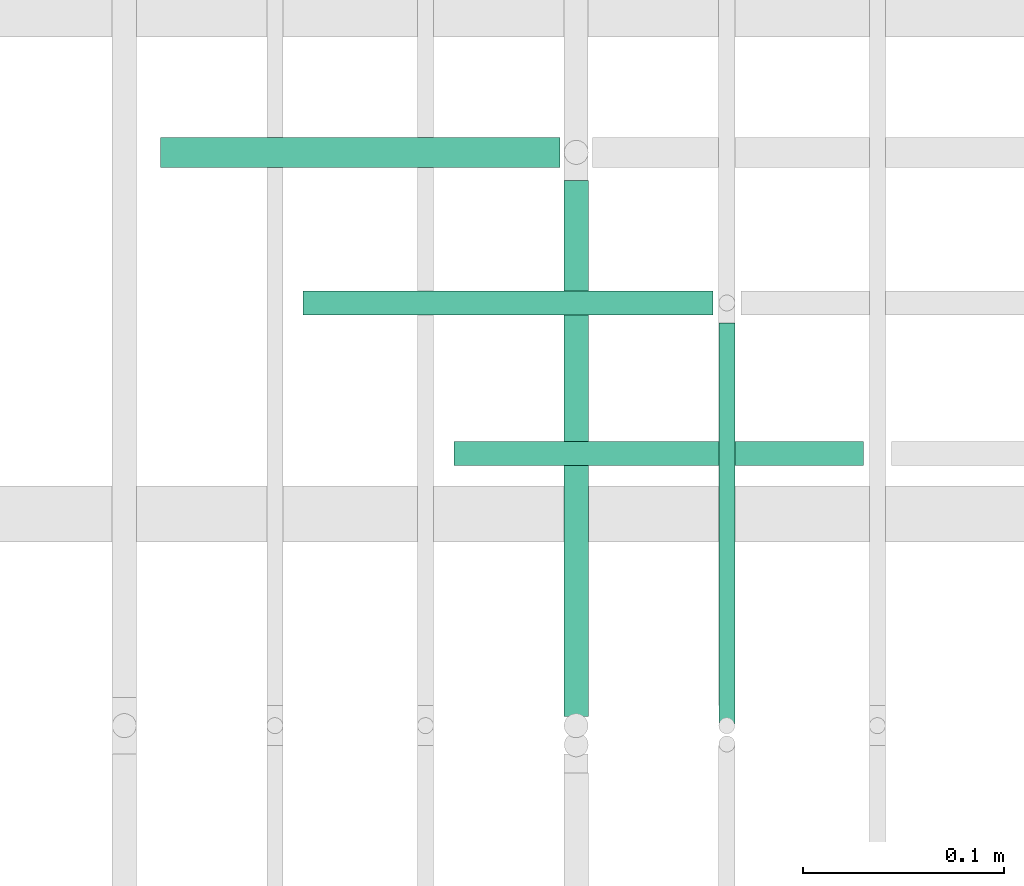
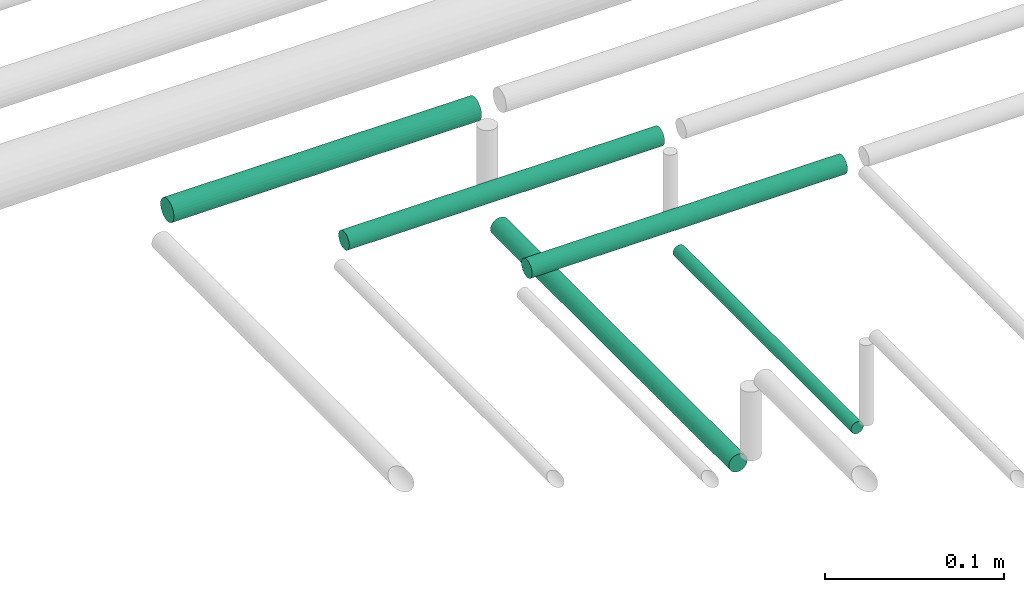
# One storey, part 191 of 331: 5 flow segments.
"""IFC2X3 building model written with IfcOpenShell, lengths in millimetres."""

import ifcopenshell
import ifcopenshell.guid

model = None  # the IFC model being written
_history = None  # IfcOwnerHistory: only IFC2X3 demands one
_inside = {}  # id of a spatial element -> (the spatial element, [elements in it])
_under = {}  # id of a project, library or spatial element -> (it, [spatial elements below it])
_declared = {}  # id of a project -> (the project, [libraries it declares])
_typed = {}  # id of a type object -> (the type object, [elements of that type])
_made_of = {}  # id of a material, layer set ... -> (it, [elements and type objects made of it])


def new_model(schema):
    """Start an empty IFC model of exactly this schema.

    Asked for "IFC4X3", IfcOpenShell would pick the latest addendum, in which some entities
    have other attributes; the version numbers below select the first issue.
    IFC2X3 requires an IfcOwnerHistory on every rooted entity: one is made here for all.
    """
    global model, _history
    if schema == "IFC4X3":
        model = ifcopenshell.file(schema_version=(4, 3, 0, 0))
    else:
        model = ifcopenshell.file(schema=schema)
    _inside.clear()
    _under.clear()
    _declared.clear()
    _typed.clear()
    _made_of.clear()
    _history = None
    if model.schema == "IFC2X3":
        org = make("IfcOrganization", Name="unknown")
        user = make(
            "IfcPersonAndOrganization",
            ThePerson=make("IfcPerson", FamilyName="unknown"),
            TheOrganization=org,
        )
        app = make(
            "IfcApplication",
            ApplicationDeveloper=org,
            Version="unknown",
            ApplicationFullName="unknown",
            ApplicationIdentifier="unknown",
        )
        _history = make(
            "IfcOwnerHistory",
            OwningUser=user,
            OwningApplication=app,
            ChangeAction="ADDED",
            CreationDate=0,
        )
    return model


def make(cls, **values):
    """One entity of the class cls with the attributes given. An attribute that is None is left unset."""
    return model.create_entity(
        cls, **{name: value for name, value in values.items() if value is not None}
    )


def entity(cls, *values):
    """Any entity or typed value of the class cls, its attributes in the order of the schema. None: left unset."""
    e = model.create_entity(cls)
    for i, value in enumerate(values):
        if value is not None:
            e[i] = value
    return e


def rooted(cls, **values):
    """An entity with a GlobalId (a new one), such as an element, a storey or a relation."""
    return make(cls, GlobalId=ifcopenshell.guid.new(), OwnerHistory=_history, **values)


def si_unit(unit_type, name, prefix=None):
    """IfcSIUnit, for example si_unit("LENGTHUNIT", "METRE", prefix="MILLI")."""
    return make("IfcSIUnit", UnitType=unit_type, Prefix=prefix, Name=name)


def converted_unit(unit_type, name, factor, base, dimensions=None, offset=None):
    """IfcConversionBasedUnit, such as the inch: factor (a typed value) times the base unit."""
    return make(
        "IfcConversionBasedUnit"
        if offset is None
        else "IfcConversionBasedUnitWithOffset",
        ConversionOffset=offset,
        Dimensions=None
        if dimensions is None
        else entity("IfcDimensionalExponents", *dimensions),
        UnitType=unit_type,
        Name=name,
        ConversionFactor=make(
            "IfcMeasureWithUnit", ValueComponent=factor, UnitComponent=base
        ),
    )


def derived_unit(unit_type, elements):
    """IfcDerivedUnit: a product of units, each with its exponent."""
    return make(
        "IfcDerivedUnit",
        Elements=[
            make("IfcDerivedUnitElement", Unit=unit, Exponent=power)
            for unit, power in elements
        ],
        UnitType=unit_type,
    )


def assignment(units):
    """IfcUnitAssignment: the units of a project."""
    return None if units is None else make("IfcUnitAssignment", Units=units)


def point(xyz):
    """IfcCartesianPoint."""
    return None if xyz is None else make("IfcCartesianPoint", Coordinates=xyz)


def direction(xyz):
    """IfcDirection."""
    return None if xyz is None else make("IfcDirection", DirectionRatios=xyz)


def frame(location, z_axis=None, x_axis=None):
    """IfcAxis2Placement3D, a coordinate frame: its origin and axes. An axis left out is left unset."""
    return make(
        "IfcAxis2Placement3D",
        Location=point(location),
        Axis=direction(z_axis),
        RefDirection=direction(x_axis),
    )


def frame_2d(location, x_axis=None):
    """IfcAxis2Placement2D, a coordinate frame in the plane: its origin and x axis."""
    return make(
        "IfcAxis2Placement2D", Location=point(location), RefDirection=direction(x_axis)
    )


def origin():
    """The frame at (0, 0, 0) with its axes left unset."""
    return frame((0.0, 0.0, 0.0))


def origin_2d_with_axis():
    """The frame at (0, 0) in the plane with the x axis (1, 0) written out."""
    return frame_2d((0.0, 0.0), x_axis=(1.0, 0.0))


def place(relative_to, where):
    """IfcLocalPlacement: puts the frame where relative to a parent placement (None: the world)."""
    return make(
        "IfcLocalPlacement", PlacementRelTo=relative_to, RelativePlacement=where
    )


def context(
    kind, dimensions, precision=None, world=None, true_north=None, identifier=None
):
    """IfcGeometricRepresentationContext, for example the 3D "Model" context."""
    return make(
        "IfcGeometricRepresentationContext",
        ContextIdentifier=identifier,
        ContextType=kind,
        CoordinateSpaceDimension=dimensions,
        Precision=precision,
        WorldCoordinateSystem=world,
        TrueNorth=true_north,
    )


def subcontext(parent, identifier, kind, view, scale=None):
    """IfcGeometricRepresentationSubContext, for example "Body" below "Model"."""
    return make(
        "IfcGeometricRepresentationSubContext",
        ContextIdentifier=identifier,
        ContextType=kind,
        ParentContext=parent,
        TargetScale=scale,
        TargetView=view,
    )


def project(units=None, contexts=None):
    """IfcProject with its units and contexts."""
    return rooted(
        "IfcProject",
        Name="project",
        RepresentationContexts=contexts,
        UnitsInContext=assignment(units),
    )


def spatial(cls, under=None, at=None, **own):
    """A site, building, storey or space (cls), placed at a placement, below another one or the project."""
    s = rooted(cls, ObjectPlacement=at, **own)
    if under is not None:
        _under.setdefault(under.id(), (under, []))[1].append(s)
    return s


def profile(cls, at=None, kind="AREA", **sizes):
    """A parametric profile (cls). Its sizes go by their IFC names, for example OverallWidth=200.0."""
    return make(cls, ProfileType=kind, Position=at, **sizes)


def circle(**sizes):
    """IfcCircleProfileDef."""
    return profile("IfcCircleProfileDef", **sizes)


def extrude(swept, where, along, depth):
    """IfcExtrudedAreaSolid: the profile swept, set in the frame where, extruded along a direction by depth."""
    return make(
        "IfcExtrudedAreaSolid",
        SweptArea=swept,
        Position=where,
        ExtrudedDirection=direction(along),
        Depth=depth,
    )


def shape(context_of_items, identifier, shape_type, items):
    """IfcShapeRepresentation: the items that make up one representation, for example the "Body"."""
    return make(
        "IfcShapeRepresentation",
        ContextOfItems=context_of_items,
        RepresentationIdentifier=identifier,
        RepresentationType=shape_type,
        Items=items,
    )


def made_of(thing, what):
    """Note that an element or type object is made of a material, layer set ...; save() writes the relation."""
    if what is not None:
        _made_of.setdefault(what.id(), (what, []))[1].append(thing)
    return thing


def type_object(cls, material=None, **own):
    """A type object (cls), such as IfcWallType, which elements share."""
    return made_of(rooted(cls, **own), material)


def element(
    cls,
    number,
    at=None,
    inside=None,
    cuts=None,
    type_object=None,
    material=None,
    context=None,
    identifier="Body",
    shape_type=None,
    held_by="IfcProductDefinitionShape",
    body=None,
    shapes=None,
    **own,
):
    """One element of the class cls, such as IfcWall. Its Tag is "e" and its number.

    at: its placement. inside: the storey or other place that contains it. cuts: it is an
    opening in that element (IfcRelVoidsElement). A single representation is given by context,
    identifier, shape_type and body (its items); several are given by shapes. held_by: the class
    of the entity that holds the representations. save() writes the other relations.
    """
    e = rooted(cls, Tag="e%d" % number, ObjectPlacement=at, **own)
    if body is not None:
        shapes = [shape(context, identifier, shape_type, body)]
    if shapes is not None:
        e.Representation = make(held_by, Representations=shapes)
    if inside is not None:
        _inside.setdefault(inside.id(), (inside, []))[1].append(e)
    if cuts is not None:
        rooted(
            "IfcRelVoidsElement", RelatingBuildingElement=cuts, RelatedOpeningElement=e
        )
    if type_object is not None:
        _typed.setdefault(type_object.id(), (type_object, []))[1].append(e)
    return made_of(e, material)


def aggregate(whole, parts):
    """IfcRelAggregates: a whole, such as a stair, and the parts it consists of."""
    return rooted("IfcRelAggregates", RelatingObject=whole, RelatedObjects=parts)


def save(model, path):
    """Write the relations noted so far, then the file.

    IfcRelAggregates (storeys below a building ...), IfcRelContainedInSpatialStructure (elements
    in a storey), IfcRelDefinesByType, IfcRelAssociatesMaterial and IfcRelDeclares: one each for
    every whole, place, type object, material and project.
    """
    for whole, parts in _under.values():
        aggregate(whole, parts)
    for where, things in _inside.values():
        rooted(
            "IfcRelContainedInSpatialStructure",
            RelatedElements=things,
            RelatingStructure=where,
        )
    for kind, things in _typed.values():
        rooted("IfcRelDefinesByType", RelatedObjects=things, RelatingType=kind)
    for what, things in _made_of.values():
        rooted("IfcRelAssociatesMaterial", RelatedObjects=things, RelatingMaterial=what)
    for by, libraries in _declared.values():
        rooted("IfcRelDeclares", RelatingContext=by, RelatedDefinitions=libraries)
    model.write(path)


model = new_model("IFC2X3")

# Units and contexts
model_context = context("Model", 3, precision=0.01, world=origin(), true_north=direction((6.12303176911189e-17, 1.0)))
body_context = subcontext(model_context, "Body", "Model", "MODEL_VIEW")
ifc_project = project(units=[si_unit("LENGTHUNIT", "METRE", prefix="MILLI"), si_unit("AREAUNIT", "SQUARE_METRE"), si_unit("VOLUMEUNIT", "CUBIC_METRE"), converted_unit("PLANEANGLEUNIT", "DEGREE", entity("IfcRatioMeasure", 0.0174532925199433), si_unit("PLANEANGLEUNIT", "RADIAN"), dimensions=[0, 0, 0, 0, 0, 0, 0]), si_unit("MASSUNIT", "GRAM", prefix="KILO"), derived_unit("MASSDENSITYUNIT", [(si_unit("MASSUNIT", "GRAM", prefix="KILO"), 1), (si_unit("LENGTHUNIT", "METRE"), -3)]), derived_unit("MOMENTOFINERTIAUNIT", [(si_unit("LENGTHUNIT", "METRE"), 4)]), si_unit("TIMEUNIT", "SECOND"), si_unit("FREQUENCYUNIT", "HERTZ"), si_unit("THERMODYNAMICTEMPERATUREUNIT", "DEGREE_CELSIUS"), derived_unit("THERMALTRANSMITTANCEUNIT", [(si_unit("MASSUNIT", "GRAM", prefix="KILO"), 1), (si_unit("THERMODYNAMICTEMPERATUREUNIT", "KELVIN"), -1), (si_unit("TIMEUNIT", "SECOND"), -3)]), derived_unit("VOLUMETRICFLOWRATEUNIT", [(si_unit("LENGTHUNIT", "METRE"), 3), (si_unit("TIMEUNIT", "SECOND"), -1)]), derived_unit("MASSFLOWRATEUNIT", [(si_unit("MASSUNIT", "GRAM", prefix="KILO"), 1), (si_unit("TIMEUNIT", "SECOND"), -1)]), derived_unit("ROTATIONALFREQUENCYUNIT", [(si_unit("TIMEUNIT", "SECOND"), -1)]), si_unit("ELECTRICCURRENTUNIT", "AMPERE"), si_unit("ELECTRICVOLTAGEUNIT", "VOLT"), si_unit("POWERUNIT", "WATT"), si_unit("FORCEUNIT", "NEWTON", prefix="KILO"), si_unit("ILLUMINANCEUNIT", "LUX"), si_unit("LUMINOUSFLUXUNIT", "LUMEN"), si_unit("LUMINOUSINTENSITYUNIT", "CANDELA"), derived_unit("USERDEFINED", [(si_unit("MASSUNIT", "GRAM", prefix="KILO"), -1), (si_unit("LENGTHUNIT", "METRE"), -2), (si_unit("TIMEUNIT", "SECOND"), 3), (si_unit("LUMINOUSFLUXUNIT", "LUMEN"), 1)]), derived_unit("LINEARVELOCITYUNIT", [(si_unit("LENGTHUNIT", "METRE"), 1), (si_unit("TIMEUNIT", "SECOND"), -1)]), si_unit("PRESSUREUNIT", "PASCAL"), derived_unit("USERDEFINED", [(si_unit("LENGTHUNIT", "METRE"), -2), (si_unit("MASSUNIT", "GRAM", prefix="KILO"), 1), (si_unit("TIMEUNIT", "SECOND"), -2)]), derived_unit("LINEARFORCEUNIT", [(si_unit("MASSUNIT", "GRAM", prefix="KILO"), 1), (si_unit("LENGTHUNIT", "METRE"), 1), (si_unit("TIMEUNIT", "SECOND"), -2), (si_unit("LENGTHUNIT", "METRE"), -1)]), derived_unit("PLANARFORCEUNIT", [(si_unit("MASSUNIT", "GRAM", prefix="KILO"), 1), (si_unit("LENGTHUNIT", "METRE"), 1), (si_unit("TIMEUNIT", "SECOND"), -2), (si_unit("LENGTHUNIT", "METRE"), -2)])], contexts=[model_context])

# Site, building, storey
site_placement = place(None, frame((0.0, -0.00077364408347762, 0.0)))
site = spatial("IfcSite", under=ifc_project, at=site_placement, CompositionType="ELEMENT")
building_placement = place(site_placement, origin())
building = spatial("IfcBuilding", under=site, at=building_placement, CompositionType="ELEMENT")
storey_placement = place(building_placement, origin())
storey = spatial("IfcBuildingStorey", under=building, at=storey_placement, CompositionType="ELEMENT", Elevation=0.0)

# Flow segments
pipe_segment_type = type_object("IfcPipeSegmentType", PredefinedType="NOTDEFINED")
flow_segment_1_placement = place(storey_placement, frame((44789.6371022652, 8091.00994384932, 14469.4047277641)))
element("IfcFlowSegment", 1, at=flow_segment_1_placement, inside=storey, type_object=pipe_segment_type, context=body_context, shape_type="SweptSolid", body=[
    extrude(circle(Radius=4.0, at=origin_2d_with_axis()), frame((5.59527223591499, 0.0, 5.59527223591499), z_axis=(0.0, 1.0, 0.0), x_axis=(1.0, 0.0, 0.0)), (0.0, 0.0, 1.0), 199.610619978043),
])
flow_segment_2_placement = place(storey_placement, frame((44712.6371022652, 8094.62056382736, 14467.4047277641)))
element("IfcFlowSegment", 2, at=flow_segment_2_placement, inside=storey, type_object=pipe_segment_type, context=body_context, shape_type="SweptSolid", body=[
    extrude(circle(Radius=6.0, at=origin_2d_with_axis()), frame((7.59527223591454, 0.0, 7.5952722359167), z_axis=(0.0, 1.0, 0.0), x_axis=(1.0, 0.0, 0.0)), (0.0, 0.0, 1.0), 266.999999999997),
])
flow_segment_3_placement = place(storey_placement, frame((44659.2323745011, 8218.02529159143, 14542.4047277641)))
element("IfcFlowSegment", 3, at=flow_segment_3_placement, inside=storey, type_object=pipe_segment_type, context=body_context, shape_type="SweptSolid", body=[
    extrude(circle(Radius=6.0, at=frame_2d((-1.08286712929839e-12, 0.0), x_axis=(1.0, 0.0))), frame((0.0, 7.5952722359232, 7.5952722359167), z_axis=(1.0, 0.0, 0.0), x_axis=(0.0, -1.0, 0.0)), (0.0, 0.0, 1.0), 204.000000000014),
])
flow_segment_4_placement = place(storey_placement, frame((44584.232374498, 8293.02529159144, 14542.4039458053)))
element("IfcFlowSegment", 4, at=flow_segment_4_placement, inside=storey, type_object=pipe_segment_type, context=body_context, shape_type="SweptSolid", body=[
    extrude(circle(Radius=6.0, at=frame_2d((-1.08286712929839e-12, -6.26071598431624e-33), x_axis=(1.0, 0.0))), frame((0.0, 7.59527223591454, 7.5952722359167), z_axis=(1.0, 0.0, 0.0), x_axis=(0.0, -1.0, 0.0)), (0.0, 0.0, 1.0), 203.998134661405),
])
flow_segment_5_placement = place(storey_placement, frame((44513.2323745003, 8366.52529159144, 14540.9046824926)))
element("IfcFlowSegment", 5, at=flow_segment_5_placement, inside=storey, type_object=pipe_segment_type, context=body_context, shape_type="SweptSolid", body=[
    extrude(circle(Radius=7.5, at=frame_2d((0.0, -2.16573425859679e-12), x_axis=(1.0, 0.0))), frame((0.0, 9.09527223591744, 9.09527223591419), z_axis=(1.0, 0.0, 0.0), x_axis=(0.0, -1.0, 0.0)), (0.0, 0.0, 1.0), 198.998118479586),
])

save(model, "model.ifc")
